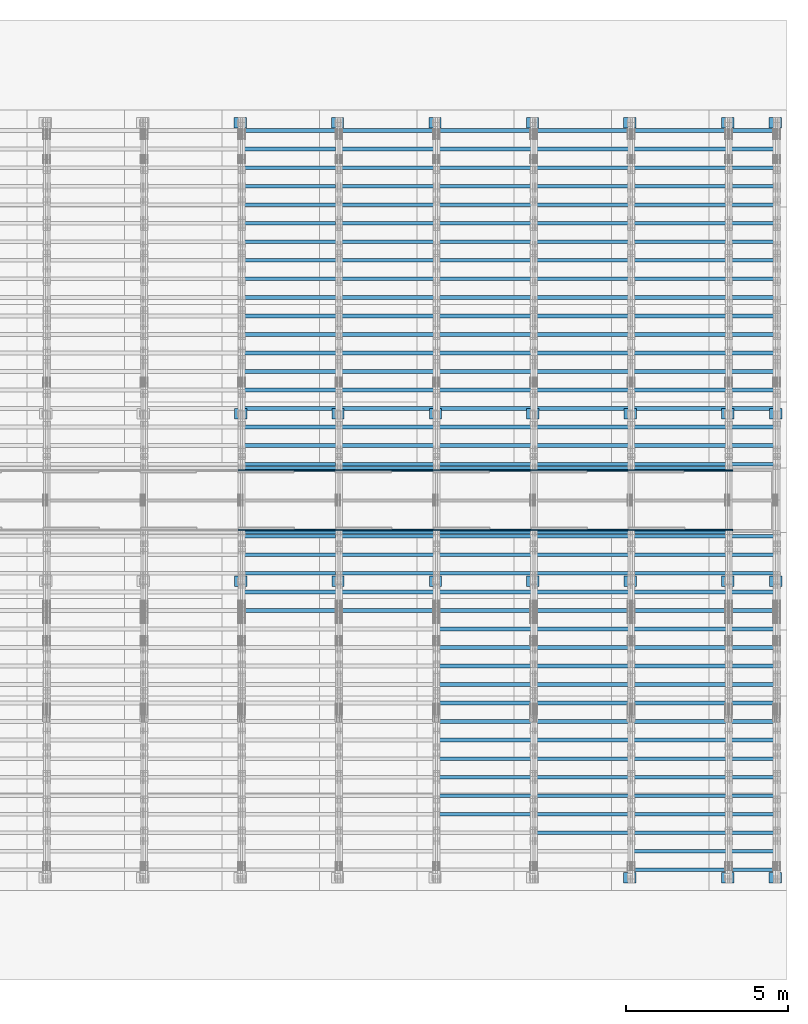
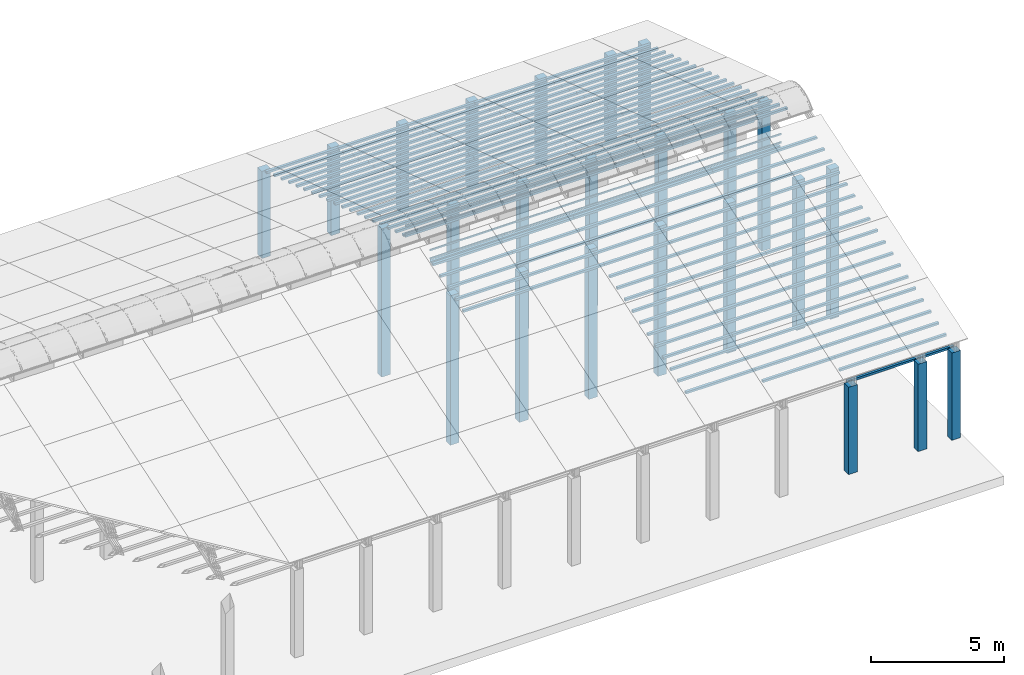
# One storey, part 4 of 385: 211 columns.
"""IFC2X3 building model written with IfcOpenShell, lengths in millimetres."""

from ifc_helpers import new_model, entity, si_unit, converted_unit, derived_unit, direction, frame, frame_2d, origin, origin_2d_with_axis, place, context, subcontext, project, spatial, rectangle, extrude, boolean, source, transform, mapped, material, type_object, type_shapes, element, save


model = new_model("IFC2X3")

# Units and contexts
model_context = context("Model", 3, precision=0.01, world=origin(), true_north=direction((6.12303176911189e-17, 1.0)))
body_context = subcontext(model_context, "Body", "Model", "MODEL_VIEW")
ifc_project = project(units=[si_unit("LENGTHUNIT", "METRE", prefix="MILLI"), si_unit("AREAUNIT", "SQUARE_METRE"), si_unit("VOLUMEUNIT", "CUBIC_METRE"), converted_unit("PLANEANGLEUNIT", "DEGREE", entity("IfcRatioMeasure", 0.0174532925199433), si_unit("PLANEANGLEUNIT", "RADIAN"), dimensions=[0, 0, 0, 0, 0, 0, 0]), si_unit("MASSUNIT", "GRAM", prefix="KILO"), derived_unit("MASSDENSITYUNIT", [(si_unit("MASSUNIT", "GRAM", prefix="KILO"), 1), (si_unit("LENGTHUNIT", "METRE"), -3)]), si_unit("TIMEUNIT", "SECOND"), si_unit("FREQUENCYUNIT", "HERTZ"), si_unit("THERMODYNAMICTEMPERATUREUNIT", "DEGREE_CELSIUS"), derived_unit("THERMALTRANSMITTANCEUNIT", [(si_unit("MASSUNIT", "GRAM", prefix="KILO"), 1), (si_unit("THERMODYNAMICTEMPERATUREUNIT", "KELVIN"), -1), (si_unit("TIMEUNIT", "SECOND"), -3)]), derived_unit("VOLUMETRICFLOWRATEUNIT", [(si_unit("LENGTHUNIT", "METRE"), 3), (si_unit("TIMEUNIT", "SECOND"), -1)]), si_unit("ELECTRICCURRENTUNIT", "AMPERE"), si_unit("ELECTRICVOLTAGEUNIT", "VOLT"), si_unit("POWERUNIT", "WATT"), si_unit("FORCEUNIT", "NEWTON", prefix="KILO"), si_unit("ILLUMINANCEUNIT", "LUX"), si_unit("LUMINOUSFLUXUNIT", "LUMEN"), si_unit("LUMINOUSINTENSITYUNIT", "CANDELA"), derived_unit("USERDEFINED", [(si_unit("MASSUNIT", "GRAM", prefix="KILO"), -1), (si_unit("LENGTHUNIT", "METRE"), -2), (si_unit("TIMEUNIT", "SECOND"), 3), (si_unit("LUMINOUSFLUXUNIT", "LUMEN"), 1)]), derived_unit("LINEARVELOCITYUNIT", [(si_unit("LENGTHUNIT", "METRE"), 1), (si_unit("TIMEUNIT", "SECOND"), -1)]), si_unit("PRESSUREUNIT", "PASCAL"), derived_unit("USERDEFINED", [(si_unit("LENGTHUNIT", "METRE"), -2), (si_unit("MASSUNIT", "GRAM", prefix="KILO"), 1), (si_unit("TIMEUNIT", "SECOND"), -2)])], contexts=[model_context])

# Site, building, storey
site_placement = place(None, origin())
site = spatial("IfcSite", under=ifc_project, at=site_placement, CompositionType="ELEMENT")
building_placement = place(site_placement, origin())
building = spatial("IfcBuilding", under=site, at=building_placement, CompositionType="ELEMENT")
storey_placement = place(building_placement, origin())
storey = spatial("IfcBuildingStorey", under=building, at=storey_placement, Name="Default", CompositionType="ELEMENT", Elevation=0.0)

# Columns
ifc_material_1 = material()
column_type_1 = type_object("IfcColumnType", Name="200x200", PredefinedType="COLUMN")
shared_shape_1 = source(origin(), body_context, "Body", "SweptSolid", [
    extrude(rectangle(XDim=379.999999999997, YDim=320.000000000004, at=origin_2d_with_axis()), frame((160.0, 300.0, -4000.0), z_axis=(0.0, 0.0, 1.0), x_axis=(0.0, -1.0, 0.0)), (0.0, 0.0, 1.0), 4000.0),
])
type_shapes(column_type_1, [shared_shape_1])
for number, where, z_axis, x_axis, name in (
    (1, (33535.0, 26180.0, 0.0), (0.0, 0.0, 1.0), (0.0, 1.0, 0.0), "V:200x200"),
    (2, (36535.0, 26180.0, 0.0), (0.0, 0.0, 1.0), (0.0, 1.0, 0.0), "V:200x200"),
    (3, (39535.0, 26180.0, 0.0), (0.0, 0.0, 1.0), (0.0, 1.0, 0.0), "V:200x200"),
    (4, (42535.0, 26180.0, 0.0), (0.0, 0.0, 1.0), (0.0, 1.0, 0.0), "V:200x200"),
    (5, (45535.0, 26180.0, 0.0), (0.0, 0.0, 1.0), (0.0, 1.0, 0.0), "V:200x200"),
    (6, (45535.0, 2940.0, 0.0), (0.0, 0.0, 1.0), (0.0, 1.0, 0.0), "V:200x200"),
    (7, (48550.0, 26180.0, 0.0), (0.0, 0.0, 1.0), (0.0, 1.0, 0.0), "V:200x200"),
    (8, (48550.0, 2940.0, 0.0), (0.0, 0.0, 1.0), (0.0, 1.0, 0.0), "V:200x200"),
    (9, (50010.0, 26180.0, 0.0), (0.0, 0.0, 1.0), (0.0, 1.0, 0.0), "V:200x200"),
    (10, (50010.0, 2940.0, 0.0), (0.0, 0.0, 1.0), (0.0, 1.0, 0.0), "V:200x200"),
):
    element("IfcColumn", number, at=place(storey_placement, frame(where, z_axis=z_axis, x_axis=x_axis)), inside=storey, type_object=column_type_1, material=ifc_material_1, Name=name, ObjectType="V:200x200", context=body_context, shape_type="MappedRepresentation", body=[
        mapped(shared_shape_1, transform((0.0, 0.0, 0.0), scale=1.0)),
    ])
column_type_2 = type_object("IfcColumnType", Name="200x200", PredefinedType="COLUMN")
shared_shape_2 = source(origin(), body_context, "Body", "SweptSolid", [
    extrude(rectangle(XDim=379.999999999997, YDim=320.000000000004, at=origin_2d_with_axis()), frame((160.0, 300.0, -4000.0), z_axis=(0.0, 0.0, 1.0), x_axis=(0.0, -1.0, 0.0)), (0.0, 0.0, 1.0), 6794.3),
])
type_shapes(column_type_2, [shared_shape_2])
for number, where, z_axis, x_axis, name in (
    (11, (33550.0, 17220.0, 0.0), (0.0, 0.0, 1.0), (0.0, 1.0, 0.0), "V:200x200"),
    (12, (36550.0, 17220.0, 0.0), (0.0, 0.0, 1.0), (0.0, 1.0, 0.0), "V:200x200"),
    (13, (39550.0, 17220.0, 0.0), (0.0, 0.0, 1.0), (0.0, 1.0, 0.0), "V:200x200"),
    (14, (42550.0, 17220.0, 0.0), (0.0, 0.0, 1.0), (0.0, 1.0, 0.0), "V:200x200"),
    (15, (45550.0, 17220.0, 0.0), (0.0, 0.0, 1.0), (0.0, 1.0, 0.0), "V:200x200"),
    (16, (48550.0, 17220.0, 0.0), (0.0, 0.0, 1.0), (0.0, 1.0, 0.0), "V:200x200"),
    (17, (50025.0, 17220.0, 0.0), (0.0, 0.0, 1.0), (0.0, 1.0, 0.0), "V:200x200"),
):
    element("IfcColumn", number, at=place(storey_placement, frame(where, z_axis=z_axis, x_axis=x_axis)), inside=storey, type_object=column_type_2, material=ifc_material_1, Name=name, ObjectType="V:200x200", context=body_context, shape_type="MappedRepresentation", body=[
        mapped(shared_shape_2, transform((0.0, 0.0, 0.0), scale=1.0)),
    ])
column_type_3 = type_object("IfcColumnType", Name="200x200", PredefinedType="COLUMN")
shared_shape_3 = source(origin(), body_context, "Body", "SweptSolid", [
    extrude(rectangle(XDim=379.999999999997, YDim=320.000000000004, at=origin_2d_with_axis()), frame((160.0, 300.0, -4000.0), z_axis=(0.0, 0.0, 1.0), x_axis=(0.0, -1.0, 0.0)), (0.0, 0.0, 1.0), 6849.5),
])
type_shapes(column_type_3, [shared_shape_3])
for number, where, z_axis, x_axis, name in (
    (18, (33550.0, 12070.0, 0.0), (0.0, 0.0, 1.0), (0.0, 1.0, 0.0), "V:200x200"),
    (19, (36550.0, 12070.0, 0.0), (0.0, 0.0, 1.0), (0.0, 1.0, 0.0), "V:200x200"),
    (20, (39550.0, 12070.0, 0.0), (0.0, 0.0, 1.0), (0.0, 1.0, 0.0), "V:200x200"),
    (21, (42550.0, 12070.0, 0.0), (0.0, 0.0, 1.0), (0.0, 1.0, 0.0), "V:200x200"),
    (22, (45550.0, 12070.0, 0.0), (0.0, 0.0, 1.0), (0.0, 1.0, 0.0), "V:200x200"),
    (23, (48550.0, 12070.0, 0.0), (0.0, 0.0, 1.0), (0.0, 1.0, 0.0), "V:200x200"),
    (24, (50025.0, 12070.0, 0.0), (0.0, 0.0, 1.0), (0.0, 1.0, 0.0), "V:200x200"),
):
    element("IfcColumn", number, at=place(storey_placement, frame(where, z_axis=z_axis, x_axis=x_axis)), inside=storey, type_object=column_type_3, material=ifc_material_1, Name=name, ObjectType="V:200x200", context=body_context, shape_type="MappedRepresentation", body=[
        mapped(shared_shape_3, transform((0.0, 0.0, 0.0), scale=1.0)),
    ])
ifc_material_2 = material(Name="2")
column_type_4 = type_object("IfcColumnType", Name="100x70", PredefinedType="COLUMN")
shared_shape_4 = source(origin(), body_context, "Body", "CSG", [
    boolean("DIFFERENCE", extrude(rectangle(XDim=3112.0299471758, YDim=116.736841236773, at=origin_2d_with_axis()), frame((1556.0149735879, 145.11006420193, -28.6286403914128)), (0.0, 0.0, 1.0), 97.4756555803792), extrude(rectangle(XDim=70.0000000018648, YDim=100.00000000027, at=frame_2d((0.0, 3.5527136788005e-15), x_axis=(0.0, 1.0))), frame((3112.0299471758, 145.11006420193, 20.1091873987768), z_axis=(1.0, 0.0, 0.0), x_axis=(0.0, 0.951056516293611, -0.309016994379696)), (0.0, 0.0, -1.0), 3112.0299471758)),
])
type_shapes(column_type_4, [shared_shape_4])
for number, where, name in (
    (25, (33175.0, 25956.5215151796, -37.9453157522206), "H_28_35_gradi:100x70"),
    (26, (33175.0, 25385.8876054038, 147.464880876897), "H_28_35_gradi:100x70"),
    (27, (33175.0, 24815.2536956269, 332.8750775022), "H_28_35_gradi:100x70"),
    (28, (33175.0, 24244.6197858498, 518.285274127168), "H_28_35_gradi:100x70"),
    (29, (33175.0, 23673.9858760727, 703.695470752224), "H_28_35_gradi:100x70"),
    (30, (33175.0, 23103.3519662956, 889.105667377245), "H_28_35_gradi:100x70"),
    (31, (33175.0, 22532.7180565186, 1074.51586400227), "H_28_35_gradi:100x70"),
    (32, (33175.0, 21962.0841467415, 1259.92606062729), "H_28_35_gradi:100x70"),
    (33, (33175.0, 21391.4502369644, 1445.33625725232), "H_28_35_gradi:100x70"),
    (34, (33175.0, 20820.8163271873, 1630.74645387734), "H_28_35_gradi:100x70"),
    (35, (33175.0, 20250.1824174102, 1816.15665050237), "H_28_35_gradi:100x70"),
    (36, (33175.0, 19679.5485076332, 2001.56684712739), "H_28_35_gradi:100x70"),
    (37, (33175.0, 19108.9145978561, 2186.97704375242), "H_28_35_gradi:100x70"),
    (38, (33175.0, 18538.280688079, 2372.38724037744), "H_28_35_gradi:100x70"),
    (39, (33175.0, 17967.646778302, 2557.79743700247), "H_28_35_gradi:100x70"),
    (40, (33175.0, 17397.0128685249, 2743.20763362749), "H_28_35_gradi:100x70"),
    (41, (33175.0, 16826.3789587478, 2928.61783025252), "H_28_35_gradi:100x70"),
    (42, (33175.0, 16255.7450489707, 3114.02802687754), "H_28_35_gradi:100x70"),
    (43, (33175.0, 15685.1111391937, 3299.43822350257), "H_28_35_gradi:100x70"),
    (44, (33175.0, 15551.9632269123, 3342.70060271507), "H_28_35_gradi:100x70"),
    (45, (36175.0, 25956.5215151796, -37.9453157522206), "H_28_35_gradi:100x70"),
    (46, (36175.0, 25385.8876054038, 147.464880876897), "H_28_35_gradi:100x70"),
    (47, (36175.0, 24815.2536956268, 332.8750775022), "H_28_35_gradi:100x70"),
    (48, (36175.0, 24244.6197858498, 518.285274127168), "H_28_35_gradi:100x70"),
    (49, (36175.0, 23673.9858760727, 703.695470752224), "H_28_35_gradi:100x70"),
    (50, (36175.0, 23103.3519662956, 889.105667377245), "H_28_35_gradi:100x70"),
    (51, (36175.0, 22532.7180565185, 1074.51586400227), "H_28_35_gradi:100x70"),
    (52, (36175.0, 21962.0841467415, 1259.92606062729), "H_28_35_gradi:100x70"),
    (53, (36175.0, 21391.4502369644, 1445.33625725232), "H_28_35_gradi:100x70"),
    (54, (36175.0, 20820.8163271873, 1630.74645387734), "H_28_35_gradi:100x70"),
    (55, (36175.0, 20250.1824174102, 1816.15665050237), "H_28_35_gradi:100x70"),
    (56, (36175.0, 19679.5485076332, 2001.56684712739), "H_28_35_gradi:100x70"),
    (57, (36175.0, 19108.9145978561, 2186.97704375242), "H_28_35_gradi:100x70"),
    (58, (36175.0, 18538.280688079, 2372.38724037744), "H_28_35_gradi:100x70"),
    (59, (36175.0, 17967.6467783019, 2557.79743700247), "H_28_35_gradi:100x70"),
    (60, (36175.0, 17397.0128685249, 2743.20763362749), "H_28_35_gradi:100x70"),
    (61, (36175.0, 16826.3789587478, 2928.61783025252), "H_28_35_gradi:100x70"),
    (62, (36175.0, 16255.7450489707, 3114.02802687754), "H_28_35_gradi:100x70"),
    (63, (36175.0, 15685.1111391937, 3299.43822350257), "H_28_35_gradi:100x70"),
    (64, (36175.0, 15551.9632269123, 3342.70060271507), "H_28_35_gradi:100x70"),
    (65, (39195.0, 25956.5215151796, -37.9453157522206), "H_28_35_gradi:100x70"),
    (66, (39195.0, 25385.8876054038, 147.464880876897), "H_28_35_gradi:100x70"),
    (67, (39195.0, 24815.2536956268, 332.8750775022), "H_28_35_gradi:100x70"),
    (68, (39195.0, 24244.6197858497, 518.285274127168), "H_28_35_gradi:100x70"),
    (69, (39195.0, 23673.9858760727, 703.695470752224), "H_28_35_gradi:100x70"),
    (70, (39195.0, 23103.3519662956, 889.105667377245), "H_28_35_gradi:100x70"),
    (71, (39195.0, 22532.7180565185, 1074.51586400227), "H_28_35_gradi:100x70"),
    (72, (39195.0, 21962.0841467415, 1259.92606062729), "H_28_35_gradi:100x70"),
    (73, (39195.0, 21391.4502369644, 1445.33625725232), "H_28_35_gradi:100x70"),
    (74, (39195.0, 20820.8163271873, 1630.74645387734), "H_28_35_gradi:100x70"),
    (75, (39195.0, 20250.1824174102, 1816.15665050237), "H_28_35_gradi:100x70"),
    (76, (39195.0, 19679.5485076332, 2001.56684712739), "H_28_35_gradi:100x70"),
    (77, (39195.0, 19108.9145978561, 2186.97704375242), "H_28_35_gradi:100x70"),
    (78, (39195.0, 18538.280688079, 2372.38724037744), "H_28_35_gradi:100x70"),
    (79, (39195.0, 17967.6467783019, 2557.79743700247), "H_28_35_gradi:100x70"),
    (80, (39195.0, 17397.0128685249, 2743.20763362749), "H_28_35_gradi:100x70"),
    (81, (39195.0, 16826.3789587478, 2928.61783025252), "H_28_35_gradi:100x70"),
    (82, (39195.0, 16255.7450489707, 3114.02802687754), "H_28_35_gradi:100x70"),
    (83, (39195.0, 15685.1111391936, 3299.43822350257), "H_28_35_gradi:100x70"),
    (84, (39195.0, 15551.9632269123, 3342.70060271507), "H_28_35_gradi:100x70"),
    (85, (42195.0, 25956.5215151796, -37.9453157522206), "H_28_35_gradi:100x70"),
    (86, (42195.0, 25385.8876054038, 147.464880876897), "H_28_35_gradi:100x70"),
    (87, (42195.0, 24815.2536956268, 332.8750775022), "H_28_35_gradi:100x70"),
    (88, (42195.0, 24244.6197858497, 518.285274127168), "H_28_35_gradi:100x70"),
    (89, (42195.0, 23673.9858760727, 703.695470752224), "H_28_35_gradi:100x70"),
    (90, (42195.0, 23103.3519662956, 889.105667377245), "H_28_35_gradi:100x70"),
    (91, (42195.0, 22532.7180565185, 1074.51586400227), "H_28_35_gradi:100x70"),
    (92, (42195.0, 21962.0841467415, 1259.92606062729), "H_28_35_gradi:100x70"),
    (93, (42195.0, 21391.4502369644, 1445.33625725232), "H_28_35_gradi:100x70"),
    (94, (42195.0, 20820.8163271873, 1630.74645387734), "H_28_35_gradi:100x70"),
    (95, (42195.0, 20250.1824174102, 1816.15665050237), "H_28_35_gradi:100x70"),
    (96, (42195.0, 19679.5485076332, 2001.56684712739), "H_28_35_gradi:100x70"),
    (97, (42195.0, 19108.9145978561, 2186.97704375242), "H_28_35_gradi:100x70"),
    (98, (42195.0, 18538.280688079, 2372.38724037744), "H_28_35_gradi:100x70"),
    (99, (42195.0, 17967.6467783019, 2557.79743700247), "H_28_35_gradi:100x70"),
    (100, (42195.0, 17397.0128685249, 2743.20763362749), "H_28_35_gradi:100x70"),
    (101, (42195.0, 16826.3789587478, 2928.61783025252), "H_28_35_gradi:100x70"),
    (102, (42195.0, 16255.7450489707, 3114.02802687754), "H_28_35_gradi:100x70"),
    (103, (42195.0, 15685.1111391936, 3299.43822350257), "H_28_35_gradi:100x70"),
    (104, (42195.0, 15551.9632269123, 3342.70060271507), "H_28_35_gradi:100x70"),
    (105, (45195.0, 15551.9632269123, 3342.70060271507), "H_28_35_gradi:100x70"),
):
    element("IfcColumn", number, at=place(storey_placement, frame(where)), inside=storey, type_object=column_type_4, material=ifc_material_2, Name=name, ObjectType="H_28_35_gradi:100x70", context=body_context, shape_type="MappedRepresentation", body=[
        mapped(shared_shape_4, transform((0.0, 0.0, 0.0), scale=1.0)),
    ])
column_type_5 = type_object("IfcColumnType", Name="100x70", PredefinedType="COLUMN")
shared_shape_5 = source(origin(), body_context, "Body", "CSG", [
    boolean("DIFFERENCE", extrude(rectangle(XDim=3112.0299471758, YDim=116.736841236773, at=origin_2d_with_axis()), frame((1556.0149735879, -145.11006420193, -28.6286403914128)), (0.0, 0.0, 1.0), 97.4756555803792), extrude(rectangle(XDim=70.0000000018648, YDim=100.00000000027, at=frame_2d((0.0, 3.5527136788005e-15), x_axis=(0.0, 1.0))), frame((0.0, -145.11006420193, 20.1091873987768), z_axis=(-1.0, 0.0, 0.0), x_axis=(0.0, -0.951056516293611, -0.309016994379696)), (0.0, 0.0, -1.0), 3112.0299471758)),
])
type_shapes(column_type_5, [shared_shape_5])
for number, where, name in (
    (106, (33175.0, 11472.3530522482, 2557.79743700247), "H_28_35_gradi:100x70"),
    (107, (33175.0, 12042.9869620252, 2743.20763362749), "H_28_35_gradi:100x70"),
    (108, (33175.0, 12613.6208718023, 2928.61783025252), "H_28_35_gradi:100x70"),
    (109, (33175.0, 13184.2547815794, 3114.02802687754), "H_28_35_gradi:100x70"),
    (110, (33175.0, 13754.8886913565, 3299.43822350257), "H_28_35_gradi:100x70"),
    (111, (33175.0, 13888.0366036378, 3342.70060271507), "H_28_35_gradi:100x70"),
    (112, (36175.0, 11472.3530522482, 2557.79743700247), "H_28_35_gradi:100x70"),
    (113, (36175.0, 12042.9869620252, 2743.20763362749), "H_28_35_gradi:100x70"),
    (114, (36175.0, 12613.6208718023, 2928.61783025252), "H_28_35_gradi:100x70"),
    (115, (36175.0, 13184.2547815794, 3114.02802687754), "H_28_35_gradi:100x70"),
    (116, (36175.0, 13754.8886913564, 3299.43822350257), "H_28_35_gradi:100x70"),
    (117, (36175.0, 13888.0366036378, 3342.70060271507), "H_28_35_gradi:100x70"),
    (118, (39195.0, 5195.38004470033, 518.285274127168), "H_28_35_gradi:100x70"),
    (119, (39195.0, 5766.01395447739, 703.695470752224), "H_28_35_gradi:100x70"),
    (120, (39195.0, 6336.64786425447, 889.105667377245), "H_28_35_gradi:100x70"),
    (121, (39195.0, 6907.28177403154, 1074.51586400227), "H_28_35_gradi:100x70"),
    (122, (39195.0, 7477.91568380862, 1259.92606062729), "H_28_35_gradi:100x70"),
    (123, (39195.0, 8048.54959358569, 1445.33625725232), "H_28_35_gradi:100x70"),
    (124, (39195.0, 8619.18350336277, 1630.74645387734), "H_28_35_gradi:100x70"),
    (125, (39195.0, 9189.81741313984, 1816.15665050237), "H_28_35_gradi:100x70"),
    (126, (39195.0, 9760.45132291693, 2001.56684712739), "H_28_35_gradi:100x70"),
    (127, (39195.0, 10331.085232694, 2186.97704375242), "H_28_35_gradi:100x70"),
    (128, (39195.0, 10901.7191424711, 2372.38724037744), "H_28_35_gradi:100x70"),
    (129, (39195.0, 11472.3530522481, 2557.79743700247), "H_28_35_gradi:100x70"),
    (130, (39195.0, 12042.9869620252, 2743.20763362749), "H_28_35_gradi:100x70"),
    (131, (39195.0, 12613.6208718023, 2928.61783025252), "H_28_35_gradi:100x70"),
    (132, (39195.0, 13184.2547815794, 3114.02802687754), "H_28_35_gradi:100x70"),
    (133, (39195.0, 13754.8886913564, 3299.43822350257), "H_28_35_gradi:100x70"),
    (134, (39195.0, 13888.0366036378, 3342.70060271507), "H_28_35_gradi:100x70"),
    (135, (42195.0, 4624.74613492323, 332.8750775022), "H_28_35_gradi:100x70"),
    (136, (42195.0, 5195.38004470032, 518.285274127168), "H_28_35_gradi:100x70"),
    (137, (42195.0, 5766.01395447738, 703.695470752224), "H_28_35_gradi:100x70"),
    (138, (42195.0, 6336.64786425446, 889.105667377245), "H_28_35_gradi:100x70"),
    (139, (42195.0, 6907.28177403153, 1074.51586400227), "H_28_35_gradi:100x70"),
    (140, (42195.0, 7477.91568380861, 1259.92606062729), "H_28_35_gradi:100x70"),
    (141, (42195.0, 8048.54959358568, 1445.33625725232), "H_28_35_gradi:100x70"),
    (142, (42195.0, 8619.18350336276, 1630.74645387734), "H_28_35_gradi:100x70"),
    (143, (42195.0, 9189.81741313983, 1816.15665050237), "H_28_35_gradi:100x70"),
    (144, (42195.0, 9760.45132291692, 2001.56684712739), "H_28_35_gradi:100x70"),
    (145, (42195.0, 10331.085232694, 2186.97704375242), "H_28_35_gradi:100x70"),
    (146, (42195.0, 10901.7191424711, 2372.38724037744), "H_28_35_gradi:100x70"),
    (147, (42195.0, 11472.3530522481, 2557.79743700247), "H_28_35_gradi:100x70"),
    (148, (42195.0, 12042.9869620252, 2743.20763362749), "H_28_35_gradi:100x70"),
    (149, (42195.0, 12613.6208718023, 2928.61783025252), "H_28_35_gradi:100x70"),
    (150, (42195.0, 13184.2547815794, 3114.02802687754), "H_28_35_gradi:100x70"),
    (151, (42195.0, 13754.8886913564, 3299.43822350257), "H_28_35_gradi:100x70"),
    (152, (42195.0, 13888.0366036377, 3342.70060271507), "H_28_35_gradi:100x70"),
    (153, (45195.0, 13888.0366036377, 3342.70060271507), "H_28_35_gradi:100x70"),
):
    element("IfcColumn", number, at=place(storey_placement, frame(where)), inside=storey, type_object=column_type_5, material=ifc_material_2, Name=name, ObjectType="H_28_35_gradi:100x70", context=body_context, shape_type="MappedRepresentation", body=[
        mapped(shared_shape_5, transform((0.0, 0.0, 0.0), scale=1.0)),
    ])
column_type_6 = type_object("IfcColumnType", Name="70x45", PredefinedType="COLUMN")
shared_shape_6 = source(origin(), body_context, "Body", "SweptSolid", [
    extrude(rectangle(XDim=45.0, YDim=3207.99969607346, at=frame_2d((-1.59872115546023e-14, 0.0), x_axis=(1.0, 0.0))), frame((1603.99984803673, 250.323014276398, 0.0), z_axis=(0.0, 0.0, 1.0), x_axis=(0.0, -1.0, 0.0)), (0.0, 0.0, 1.0), 69.9999999999776),
])
type_shapes(column_type_6, [shared_shape_6])
for number, where, z_axis, x_axis, name in (
    (154, (36382.9996960735, 15887.8230423367, 3436.65682464217), (0.0, 0.0, 1.0), (-1.0, 0.0, 0.0), "H1:70x45"),
    (155, (36382.9996960735, 15887.8230423367, 3821.65682464217), (0.0, 0.0, 1.0), (-1.0, 0.0, 0.0), "H1:70x45"),
    (156, (39382.9996960735, 15887.8230423366, 3436.65682464217), (0.0, 0.0, 1.0), (-1.0, 0.0, 0.0), "H1:70x45"),
    (157, (39382.9996960735, 15887.8230423366, 3821.65682464217), (0.0, 0.0, 1.0), (-1.0, 0.0, 0.0), "H1:70x45"),
    (158, (42402.9996960735, 15887.8230423366, 3436.65682464217), (0.0, 0.0, 1.0), (-1.0, 0.0, 0.0), "H1:70x45"),
    (159, (42402.9996960735, 15887.8230423366, 3821.65682464217), (0.0, 0.0, 1.0), (-1.0, 0.0, 0.0), "H1:70x45"),
    (160, (45402.9996960734, 15887.8230423366, 3436.65682464217), (0.0, 0.0, 1.0), (-1.0, 0.0, 0.0), "H1:70x45"),
    (161, (45402.9996960734, 15887.8230423366, 3821.65682464217), (0.0, 0.0, 1.0), (-1.0, 0.0, 0.0), "H1:70x45"),
    (162, (48402.9996960735, 15887.8230423366, 3436.65682464217), (0.0, 0.0, 1.0), (-1.0, 0.0, 0.0), "H1:70x45"),
    (163, (48402.9996960735, 15887.8230423366, 3821.65682464217), (0.0, 0.0, 1.0), (-1.0, 0.0, 0.0), "H1:70x45"),
):
    element("IfcColumn", number, at=place(storey_placement, frame(where, z_axis=z_axis, x_axis=x_axis)), inside=storey, type_object=column_type_6, material=ifc_material_2, Name=name, ObjectType="H1:70x45", context=body_context, shape_type="MappedRepresentation", body=[
        mapped(shared_shape_6, transform((0.0, 0.0, 0.0), scale=1.0)),
    ])
column_type_7 = type_object("IfcColumnType", Name="70x45", PredefinedType="COLUMN")
shared_shape_7 = source(origin(), body_context, "Body", "SweptSolid", [
    extrude(rectangle(XDim=45.0, YDim=3215.28399061289, at=frame_2d((1.59872115546023e-14, 0.0), x_axis=(1.0, 0.0))), frame((1607.64199530645, -250.323014276398, 0.0), z_axis=(0.0, 0.0, 1.0), x_axis=(0.0, -1.0, 0.0)), (0.0, 0.0, 1.0), 69.9999999999776),
])
type_shapes(column_type_7, [shared_shape_7])
for number, where, z_axis, x_axis, name in (
    (164, (36390.2839906129, 13552.1767882135, 3436.65682464217), (0.0, 0.0, 1.0), (-1.0, 0.0, 0.0), "H1:70x45"),
    (165, (36390.2839906129, 13552.1767882135, 3821.65682464217), (0.0, 0.0, 1.0), (-1.0, 0.0, 0.0), "H1:70x45"),
    (166, (39390.2839906129, 13552.1767882134, 3436.65682464217), (0.0, 0.0, 1.0), (-1.0, 0.0, 0.0), "H1:70x45"),
    (167, (39390.2839906129, 13552.1767882134, 3821.65682464217), (0.0, 0.0, 1.0), (-1.0, 0.0, 0.0), "H1:70x45"),
    (168, (42410.2839906129, 13552.1767882134, 3436.65682464217), (0.0, 0.0, 1.0), (-1.0, 0.0, 0.0), "H1:70x45"),
    (169, (42410.2839906129, 13552.1767882134, 3821.65682464217), (0.0, 0.0, 1.0), (-1.0, 0.0, 0.0), "H1:70x45"),
    (170, (45410.2839906129, 13552.1767882134, 3436.65682464217), (0.0, 0.0, 1.0), (-1.0, 0.0, 0.0), "H1:70x45"),
    (171, (45410.2839906129, 13552.1767882134, 3821.65682464217), (0.0, 0.0, 1.0), (-1.0, 0.0, 0.0), "H1:70x45"),
    (172, (48410.2839906129, 13552.1767882134, 3436.65682464217), (0.0, 0.0, 1.0), (-1.0, 0.0, 0.0), "H1:70x45"),
    (173, (48410.2839906129, 13552.1767882134, 3821.65682464217), (0.0, 0.0, 1.0), (-1.0, 0.0, 0.0), "H1:70x45"),
):
    element("IfcColumn", number, at=place(storey_placement, frame(where, z_axis=z_axis, x_axis=x_axis)), inside=storey, type_object=column_type_7, material=ifc_material_2, Name=name, ObjectType="H1:70x45", context=body_context, shape_type="MappedRepresentation", body=[
        mapped(shared_shape_7, transform((0.0, 0.0, 0.0), scale=1.0)),
    ])
column_type_8 = type_object("IfcColumnType", Name="100x70", PredefinedType="COLUMN")
shared_shape_8 = source(origin(), body_context, "Body", "CSG", [
    boolean("DIFFERENCE", extrude(rectangle(XDim=4628.5137339823, YDim=116.736841236773, at=origin_2d_with_axis()), frame((2314.25686699115, 145.11006420193, -28.6286403914128)), (0.0, 0.0, 1.0), 97.4756555803792), extrude(rectangle(XDim=70.0000000018648, YDim=100.00000000027, at=frame_2d((0.0, 3.5527136788005e-15), x_axis=(0.0, 1.0))), frame((4628.5137339823, 145.11006420193, 20.1091873987768), z_axis=(1.0, 0.0, 0.0), x_axis=(0.0, 0.951056516293611, -0.309016994379696)), (0.0, 0.0, -1.0), 4628.5137339823)),
])
type_shapes(column_type_8, [shared_shape_8])
for number, where, name in (
    (174, (45195.0, 25956.5215151796, -37.9453157522206), "H_28_35_gradi:100x70"),
    (175, (45195.0, 25385.8876054038, 147.464880876897), "H_28_35_gradi:100x70"),
    (176, (45195.0, 24815.2536956268, 332.8750775022), "H_28_35_gradi:100x70"),
    (177, (45195.0, 24244.6197858497, 518.285274127168), "H_28_35_gradi:100x70"),
    (178, (45195.0, 23673.9858760727, 703.695470752224), "H_28_35_gradi:100x70"),
    (179, (45195.0, 23103.3519662956, 889.105667377245), "H_28_35_gradi:100x70"),
    (180, (45195.0, 22532.7180565185, 1074.51586400227), "H_28_35_gradi:100x70"),
    (181, (45195.0, 21962.0841467414, 1259.92606062729), "H_28_35_gradi:100x70"),
    (182, (45195.0, 21391.4502369644, 1445.33625725232), "H_28_35_gradi:100x70"),
    (183, (45195.0, 20820.8163271873, 1630.74645387734), "H_28_35_gradi:100x70"),
    (184, (45195.0, 20250.1824174102, 1816.15665050237), "H_28_35_gradi:100x70"),
    (185, (45195.0, 19679.5485076331, 2001.56684712739), "H_28_35_gradi:100x70"),
    (186, (45195.0, 19108.9145978561, 2186.97704375242), "H_28_35_gradi:100x70"),
    (187, (45195.0, 18538.280688079, 2372.38724037744), "H_28_35_gradi:100x70"),
    (188, (45195.0, 17967.6467783019, 2557.79743700247), "H_28_35_gradi:100x70"),
    (189, (45195.0, 17397.0128685248, 2743.20763362749), "H_28_35_gradi:100x70"),
    (190, (45195.0, 16826.3789587478, 2928.61783025252), "H_28_35_gradi:100x70"),
    (191, (45195.0, 16255.7450489707, 3114.02802687754), "H_28_35_gradi:100x70"),
    (192, (45195.0, 15685.1111391936, 3299.43822350257), "H_28_35_gradi:100x70"),
):
    element("IfcColumn", number, at=place(storey_placement, frame(where)), inside=storey, type_object=column_type_8, material=ifc_material_2, Name=name, ObjectType="H_28_35_gradi:100x70", context=body_context, shape_type="MappedRepresentation", body=[
        mapped(shared_shape_8, transform((0.0, 0.0, 0.0), scale=1.0)),
    ])
column_type_9 = type_object("IfcColumnType", Name="100x70", PredefinedType="COLUMN")
shared_shape_9 = source(origin(), body_context, "Body", "CSG", [
    boolean("DIFFERENCE", extrude(rectangle(XDim=4628.51373398229, YDim=116.736841236773, at=origin_2d_with_axis()), frame((2314.25686699115, -145.11006420193, -28.6286403914128)), (0.0, 0.0, 1.0), 97.4756555803792), extrude(rectangle(XDim=70.0000000018648, YDim=100.00000000027, at=frame_2d((0.0, 3.5527136788005e-15), x_axis=(0.0, 1.0))), frame((0.0, -145.11006420193, 20.1091873987768), z_axis=(-1.0, 0.0, 0.0), x_axis=(0.0, -0.951056516293611, -0.309016994379696)), (0.0, 0.0, -1.0), 4628.51373398229)),
])
type_shapes(column_type_9, [shared_shape_9])
for number, where, name in (
    (193, (45195.0, 3483.47831537049, -37.9453157522206), "H_28_35_gradi:100x70"),
    (194, (45195.0, 4054.11222514623, 147.464880876897), "H_28_35_gradi:100x70"),
    (195, (45195.0, 4624.74613492322, 332.8750775022), "H_28_35_gradi:100x70"),
    (196, (45195.0, 5195.38004470031, 518.285274127168), "H_28_35_gradi:100x70"),
    (197, (45195.0, 5766.01395447737, 703.695470752224), "H_28_35_gradi:100x70"),
    (198, (45195.0, 6336.64786425445, 889.105667377245), "H_28_35_gradi:100x70"),
    (199, (45195.0, 6907.28177403152, 1074.51586400227), "H_28_35_gradi:100x70"),
    (200, (45195.0, 7477.9156838086, 1259.92606062729), "H_28_35_gradi:100x70"),
    (201, (45195.0, 8048.54959358567, 1445.33625725232), "H_28_35_gradi:100x70"),
    (202, (45195.0, 8619.18350336275, 1630.74645387734), "H_28_35_gradi:100x70"),
    (203, (45195.0, 9189.81741313982, 1816.15665050237), "H_28_35_gradi:100x70"),
    (204, (45195.0, 9760.45132291691, 2001.56684712739), "H_28_35_gradi:100x70"),
    (205, (45195.0, 10331.085232694, 2186.97704375242), "H_28_35_gradi:100x70"),
    (206, (45195.0, 10901.7191424711, 2372.38724037744), "H_28_35_gradi:100x70"),
    (207, (45195.0, 11472.3530522481, 2557.79743700247), "H_28_35_gradi:100x70"),
    (208, (45195.0, 12042.9869620252, 2743.20763362749), "H_28_35_gradi:100x70"),
    (209, (45195.0, 12613.6208718023, 2928.61783025252), "H_28_35_gradi:100x70"),
    (210, (45195.0, 13184.2547815794, 3114.02802687754), "H_28_35_gradi:100x70"),
    (211, (45195.0, 13754.8886913564, 3299.43822350257), "H_28_35_gradi:100x70"),
):
    element("IfcColumn", number, at=place(storey_placement, frame(where)), inside=storey, type_object=column_type_9, material=ifc_material_2, Name=name, ObjectType="H_28_35_gradi:100x70", context=body_context, shape_type="MappedRepresentation", body=[
        mapped(shared_shape_9, transform((0.0, 0.0, 0.0), scale=1.0)),
    ])

save(model, "model.ifc")
